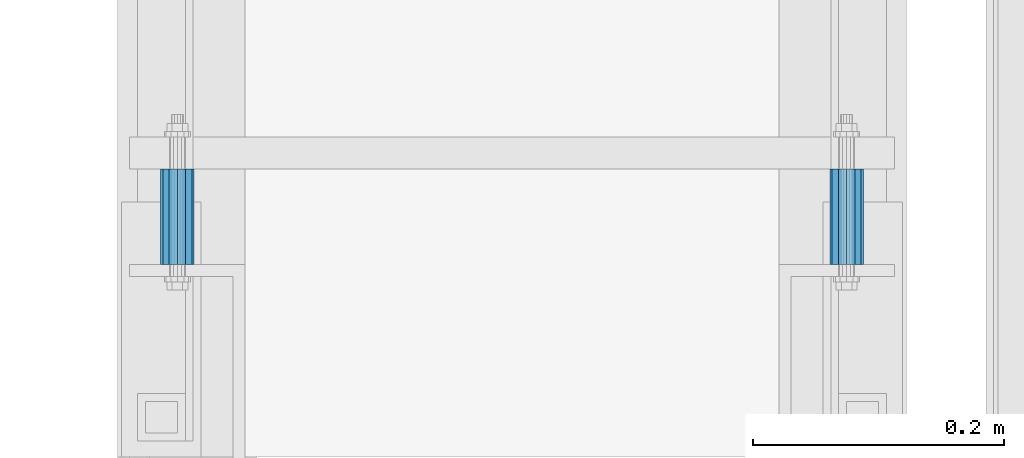
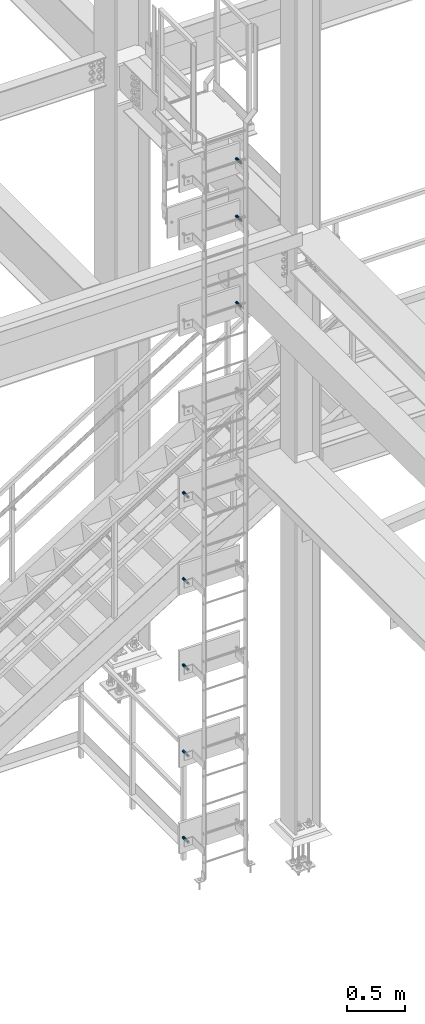
# One storey, part 2873 of 3843: 8 beams, 8 elements without a shape of their own.
"""IFC2X3 building model written with IfcOpenShell, lengths in millimetres."""

from ifc_helpers import new_model, si_unit, frame, origin_with_axes, place, context, subcontext, project, spatial, faceted_brep, material, type_object, element, aggregate, save


model = new_model("IFC2X3")

# Units and contexts
model_context = context("Model", 3, precision=1e-05, world=origin_with_axes())
body_context = subcontext(model_context, "Body", "Model", "MODEL_VIEW")
ifc_project = project(units=[si_unit("LENGTHUNIT", "METRE", prefix="MILLI"), si_unit("AREAUNIT", "SQUARE_METRE"), si_unit("VOLUMEUNIT", "CUBIC_METRE"), si_unit("MASSUNIT", "GRAM", prefix="KILO"), si_unit("TIMEUNIT", "SECOND"), si_unit("PLANEANGLEUNIT", "RADIAN"), si_unit("SOLIDANGLEUNIT", "STERADIAN"), si_unit("THERMODYNAMICTEMPERATUREUNIT", "DEGREE_CELSIUS"), si_unit("LUMINOUSINTENSITYUNIT", "LUMEN")], contexts=[model_context])

# Site, building, storey
site_placement = place(None, origin_with_axes())
site = spatial("IfcSite", under=ifc_project, at=site_placement, CompositionType="ELEMENT")
building_placement = place(site_placement, origin_with_axes())
building = spatial("IfcBuilding", under=site, at=building_placement, Name="Undefined", CompositionType="ELEMENT")
storey_placement = place(building_placement, origin_with_axes())
storey = spatial("IfcBuildingStorey", under=building, at=storey_placement, Name="Undefined", CompositionType="ELEMENT", Elevation=0.0)

# Assembly, beam
assembly_1_placement = place(storey_placement, origin_with_axes())
assembly_1 = element("IfcElementAssembly", 1, at=assembly_1_placement, inside=storey, Name="SLEEVE", AssemblyPlace="NOTDEFINED", PredefinedType="RIGID_FRAME")
ifc_material = material()
beam_type = type_object("IfcBeamType", Name="PIPE3/4SCH40", PredefinedType="NOTDEFINED")
beam_1_placement = place(assembly_1_placement, frame((35623.4999231775, 88507.0189660453, 37797.6364425983), z_axis=(0.0, 2.02899999567308e-06, 0.999999999997942), x_axis=(0.0, 0.999999999997942, -2.02899998962774e-06)))
beam_1 = element("IfcBeam", 2, at=beam_1_placement, type_object=beam_type, material=ifc_material, Name="SLEEVE", ObjectType="PIPE3/4SCH40", context=body_context, shape_type="Brep", body=[
    faceted_brep([(0.0, -10.4648000000016, 7.27595761418343e-12), (-7.27595761418343e-12, -9.06278264552384, 5.23240000000806), (76.2000000004009, -9.06278264552384, 5.2324000001172), (76.2000000004045, -10.4648000000016, 1.16415321826935e-10), (-1.45519152283669e-11, -5.23240000000078, 9.06278264553839), (76.20000000039, -5.23240000000078, 9.06278264564753), (-1.45519152283669e-11, 0.0, 10.4648000000161), (76.20000000039, 0.0, 10.4648000001253), (-1.45519152283669e-11, 5.23240000000078, 9.06278264553839), (76.20000000039, 5.23240000000078, 9.06278264564753), (-7.27595761418343e-12, 9.06278264552384, 5.23240000000806), (76.2000000004009, 9.06278264552384, 5.2324000001172), (0.0, 10.4648000000016, 7.27595761418343e-12), (76.2000000004045, 10.4648000000016, 1.16415321826935e-10), (1.09139364212751e-11, 9.06278264552384, -5.2323999999935), (76.2000000004155, 9.06278264552384, -5.23239999988436), (1.45519152283669e-11, 5.23240000000078, -9.06278264551656), (76.2000000004191, 5.23240000000078, -9.06278264540742), (1.45519152283669e-11, 0.0, -10.4647999999943), (76.2000000004191, 0.0, -10.4647999998851), (1.45519152283669e-11, -5.23240000000078, -9.06278264551656), (76.2000000004191, -5.23240000000078, -9.06278264540742), (1.09139364212751e-11, -9.06278264552384, -5.2323999999935), (76.2000000004155, -9.06278264552384, -5.23239999988436), (0.0, -13.3349999999991, 7.27595761418343e-12), (1.09139364212751e-11, -11.5484487594658, -6.66749999999593), (76.2000000004155, -11.5484487594658, -6.66749999988679), (76.2000000004045, -13.3349999999991, 1.16415321826935e-10), (1.45519152283669e-11, -6.66749999999956, -11.5484487594586), (76.2000000004191, -6.66749999999956, -11.5484487593494), (1.81898940354586e-11, 0.0, -13.3349999999919), (76.2000000004227, 0.0, -13.3349999998827), (1.45519152283669e-11, 6.66749999999956, -11.5484487594586), (76.2000000004191, 6.66749999999956, -11.5484487593494), (1.09139364212751e-11, 11.5484487594658, -6.66749999999593), (76.2000000004155, 11.5484487594658, -6.66749999988679), (0.0, 13.3349999999991, 7.27595761418343e-12), (76.2000000004045, 13.3349999999991, 1.16415321826935e-10), (-7.27595761418343e-12, 11.5484487594658, 6.66750000001048), (76.2000000003973, 11.5484487594658, 6.66750000011234), (-1.45519152283669e-11, 6.66749999999956, 11.5484487594804), (76.20000000039, 6.66749999999956, 11.5484487595895), (-1.81898940354586e-11, 0.0, 13.3350000000137), (76.2000000003864, 0.0, 13.3350000001228), (-1.45519152283669e-11, -6.66749999999956, 11.5484487594804), (76.20000000039, -6.66749999999956, 11.5484487595895), (-7.27595761418343e-12, -11.5484487594658, 6.66750000001048), (76.2000000003973, -11.5484487594658, 6.66750000011234)], [[[0, 1, 2, 3]], [[1, 4, 5, 2]], [[4, 6, 7, 5]], [[6, 8, 9, 7]], [[8, 10, 11, 9]], [[10, 12, 13, 11]], [[12, 14, 15, 13]], [[14, 16, 17, 15]], [[16, 18, 19, 17]], [[18, 20, 21, 19]], [[20, 22, 23, 21]], [[22, 0, 3, 23]], [[24, 25, 26, 27]], [[25, 28, 29, 26]], [[28, 30, 31, 29]], [[30, 32, 33, 31]], [[32, 34, 35, 33]], [[34, 36, 37, 35]], [[36, 38, 39, 37]], [[38, 40, 41, 39]], [[40, 42, 43, 41]], [[42, 44, 45, 43]], [[44, 46, 47, 45]], [[46, 24, 27, 47]], [[29, 31, 33, 35, 37, 39, 41, 43, 45, 47, 27, 26], [5, 7, 9, 11, 13, 15, 17, 19, 21, 23, 3, 2]], [[46, 44, 42, 40, 38, 36, 34, 32, 30, 28, 25, 24], [22, 20, 18, 16, 14, 12, 10, 8, 6, 4, 1, 0]]]),
])
aggregate(assembly_1, [beam_1])

assembly_2_placement = place(storey_placement, origin_with_axes())
assembly_2 = element("IfcElementAssembly", 3, at=assembly_2_placement, inside=storey, Name="SLEEVE", AssemblyPlace="NOTDEFINED", PredefinedType="RIGID_FRAME")
beam_2_placement = place(assembly_2_placement, frame((35623.4999231775, 88507.0189660453, 37188.0364425983), z_axis=(0.0, 2.02899999567308e-06, 0.999999999997942), x_axis=(0.0, 0.999999999997942, -2.02899998962774e-06)))
beam_2 = element("IfcBeam", 4, at=beam_2_placement, type_object=beam_type, material=ifc_material, Name="SLEEVE", ObjectType="PIPE3/4SCH40", context=body_context, shape_type="Brep", body=[
    faceted_brep([(0.0, -10.4648000000016, 7.27595761418343e-12), (-7.27595761418343e-12, -9.06278264552384, 5.23240000000806), (76.2000000004009, -9.06278264552384, 5.2324000001172), (76.2000000004045, -10.4648000000016, 1.16415321826935e-10), (-1.45519152283669e-11, -5.23240000000078, 9.06278264553839), (76.20000000039, -5.23240000000078, 9.06278264564753), (-1.45519152283669e-11, 0.0, 10.4648000000161), (76.20000000039, 0.0, 10.4648000001253), (-1.45519152283669e-11, 5.23240000000078, 9.06278264553839), (76.20000000039, 5.23240000000078, 9.06278264564753), (-7.27595761418343e-12, 9.06278264552384, 5.23240000000806), (76.2000000004009, 9.06278264552384, 5.2324000001172), (0.0, 10.4648000000016, 7.27595761418343e-12), (76.2000000004045, 10.4648000000016, 1.16415321826935e-10), (1.09139364212751e-11, 9.06278264552384, -5.2323999999935), (76.2000000004155, 9.06278264552384, -5.23239999988436), (1.45519152283669e-11, 5.23240000000078, -9.06278264551656), (76.2000000004191, 5.23240000000078, -9.06278264540742), (1.45519152283669e-11, 0.0, -10.4647999999943), (76.2000000004191, 0.0, -10.4647999998851), (1.45519152283669e-11, -5.23240000000078, -9.06278264551656), (76.2000000004191, -5.23240000000078, -9.06278264540742), (1.09139364212751e-11, -9.06278264552384, -5.2323999999935), (76.2000000004155, -9.06278264552384, -5.23239999988436), (0.0, -13.3349999999991, 7.27595761418343e-12), (1.09139364212751e-11, -11.5484487594658, -6.66749999999593), (76.2000000004155, -11.5484487594658, -6.66749999988679), (76.2000000004045, -13.3349999999991, 1.16415321826935e-10), (1.45519152283669e-11, -6.66749999999956, -11.5484487594586), (76.2000000004191, -6.66749999999956, -11.5484487593494), (1.81898940354586e-11, 0.0, -13.3349999999919), (76.2000000004227, 0.0, -13.3349999998827), (1.45519152283669e-11, 6.66749999999956, -11.5484487594586), (76.2000000004191, 6.66749999999956, -11.5484487593494), (1.09139364212751e-11, 11.5484487594658, -6.66749999999593), (76.2000000004155, 11.5484487594658, -6.66749999988679), (0.0, 13.3349999999991, 7.27595761418343e-12), (76.2000000004045, 13.3349999999991, 1.16415321826935e-10), (-7.27595761418343e-12, 11.5484487594658, 6.66750000001048), (76.2000000003973, 11.5484487594658, 6.66750000011234), (-1.45519152283669e-11, 6.66749999999956, 11.5484487594804), (76.20000000039, 6.66749999999956, 11.5484487595895), (-1.81898940354586e-11, 0.0, 13.3350000000137), (76.2000000003864, 0.0, 13.3350000001228), (-1.45519152283669e-11, -6.66749999999956, 11.5484487594804), (76.20000000039, -6.66749999999956, 11.5484487595895), (-7.27595761418343e-12, -11.5484487594658, 6.66750000001048), (76.2000000003973, -11.5484487594658, 6.66750000011234)], [[[0, 1, 2, 3]], [[1, 4, 5, 2]], [[4, 6, 7, 5]], [[6, 8, 9, 7]], [[8, 10, 11, 9]], [[10, 12, 13, 11]], [[12, 14, 15, 13]], [[14, 16, 17, 15]], [[16, 18, 19, 17]], [[18, 20, 21, 19]], [[20, 22, 23, 21]], [[22, 0, 3, 23]], [[24, 25, 26, 27]], [[25, 28, 29, 26]], [[28, 30, 31, 29]], [[30, 32, 33, 31]], [[32, 34, 35, 33]], [[34, 36, 37, 35]], [[36, 38, 39, 37]], [[38, 40, 41, 39]], [[40, 42, 43, 41]], [[42, 44, 45, 43]], [[44, 46, 47, 45]], [[46, 24, 27, 47]], [[29, 31, 33, 35, 37, 39, 41, 43, 45, 47, 27, 26], [5, 7, 9, 11, 13, 15, 17, 19, 21, 23, 3, 2]], [[46, 44, 42, 40, 38, 36, 34, 32, 30, 28, 25, 24], [22, 20, 18, 16, 14, 12, 10, 8, 6, 4, 1, 0]]]),
])
aggregate(assembly_2, [beam_2])

assembly_3_placement = place(storey_placement, origin_with_axes())
assembly_3 = element("IfcElementAssembly", 5, at=assembly_3_placement, inside=storey, Name="SLEEVE", AssemblyPlace="NOTDEFINED", PredefinedType="RIGID_FRAME")
beam_3_placement = place(assembly_3_placement, frame((35623.4999231775, 88507.0189660453, 36273.6364425983), z_axis=(0.0, 2.02899999567308e-06, 0.999999999997942), x_axis=(0.0, 0.999999999997942, -2.02899998962774e-06)))
beam_3 = element("IfcBeam", 6, at=beam_3_placement, type_object=beam_type, material=ifc_material, Name="SLEEVE", ObjectType="PIPE3/4SCH40", context=body_context, shape_type="Brep", body=[
    faceted_brep([(0.0, -10.4648000000016, 7.27595761418343e-12), (-7.27595761418343e-12, -9.06278264552384, 5.23240000000806), (76.2000000004009, -9.06278264552384, 5.2324000001172), (76.2000000004045, -10.4648000000016, 1.16415321826935e-10), (-1.45519152283669e-11, -5.23240000000078, 9.06278264553839), (76.20000000039, -5.23240000000078, 9.06278264564753), (-1.45519152283669e-11, 0.0, 10.4648000000161), (76.20000000039, 0.0, 10.4648000001253), (-1.45519152283669e-11, 5.23240000000078, 9.06278264553839), (76.20000000039, 5.23240000000078, 9.06278264564753), (-7.27595761418343e-12, 9.06278264552384, 5.23240000000806), (76.2000000004009, 9.06278264552384, 5.2324000001172), (0.0, 10.4648000000016, 7.27595761418343e-12), (76.2000000004045, 10.4648000000016, 1.16415321826935e-10), (1.09139364212751e-11, 9.06278264552384, -5.2323999999935), (76.2000000004155, 9.06278264552384, -5.23239999988436), (1.45519152283669e-11, 5.23240000000078, -9.06278264551656), (76.2000000004191, 5.23240000000078, -9.06278264540742), (1.45519152283669e-11, 0.0, -10.4647999999943), (76.2000000004191, 0.0, -10.4647999998851), (1.45519152283669e-11, -5.23240000000078, -9.06278264551656), (76.2000000004191, -5.23240000000078, -9.06278264540742), (1.09139364212751e-11, -9.06278264552384, -5.2323999999935), (76.2000000004155, -9.06278264552384, -5.23239999988436), (0.0, -13.3349999999991, 7.27595761418343e-12), (1.09139364212751e-11, -11.5484487594658, -6.66749999999593), (76.2000000004155, -11.5484487594658, -6.66749999988679), (76.2000000004045, -13.3349999999991, 1.16415321826935e-10), (1.45519152283669e-11, -6.66749999999956, -11.5484487594586), (76.2000000004191, -6.66749999999956, -11.5484487593494), (1.81898940354586e-11, 0.0, -13.3349999999919), (76.2000000004227, 0.0, -13.3349999998827), (1.45519152283669e-11, 6.66749999999956, -11.5484487594586), (76.2000000004191, 6.66749999999956, -11.5484487593494), (1.09139364212751e-11, 11.5484487594658, -6.66749999999593), (76.2000000004155, 11.5484487594658, -6.66749999988679), (0.0, 13.3349999999991, 7.27595761418343e-12), (76.2000000004045, 13.3349999999991, 1.16415321826935e-10), (-7.27595761418343e-12, 11.5484487594658, 6.66750000001048), (76.2000000003973, 11.5484487594658, 6.66750000011234), (-1.45519152283669e-11, 6.66749999999956, 11.5484487594804), (76.20000000039, 6.66749999999956, 11.5484487595895), (-1.81898940354586e-11, 0.0, 13.3350000000137), (76.2000000003864, 0.0, 13.3350000001228), (-1.45519152283669e-11, -6.66749999999956, 11.5484487594804), (76.20000000039, -6.66749999999956, 11.5484487595895), (-7.27595761418343e-12, -11.5484487594658, 6.66750000001048), (76.2000000003973, -11.5484487594658, 6.66750000011234)], [[[0, 1, 2, 3]], [[1, 4, 5, 2]], [[4, 6, 7, 5]], [[6, 8, 9, 7]], [[8, 10, 11, 9]], [[10, 12, 13, 11]], [[12, 14, 15, 13]], [[14, 16, 17, 15]], [[16, 18, 19, 17]], [[18, 20, 21, 19]], [[20, 22, 23, 21]], [[22, 0, 3, 23]], [[24, 25, 26, 27]], [[25, 28, 29, 26]], [[28, 30, 31, 29]], [[30, 32, 33, 31]], [[32, 34, 35, 33]], [[34, 36, 37, 35]], [[36, 38, 39, 37]], [[38, 40, 41, 39]], [[40, 42, 43, 41]], [[42, 44, 45, 43]], [[44, 46, 47, 45]], [[46, 24, 27, 47]], [[29, 31, 33, 35, 37, 39, 41, 43, 45, 47, 27, 26], [5, 7, 9, 11, 13, 15, 17, 19, 21, 23, 3, 2]], [[46, 44, 42, 40, 38, 36, 34, 32, 30, 28, 25, 24], [22, 20, 18, 16, 14, 12, 10, 8, 6, 4, 1, 0]]]),
])
aggregate(assembly_3, [beam_3])

assembly_4_placement = place(storey_placement, origin_with_axes())
assembly_4 = element("IfcElementAssembly", 7, at=assembly_4_placement, inside=storey, Name="SLEEVE", AssemblyPlace="NOTDEFINED", PredefinedType="RIGID_FRAME")
beam_4_placement = place(assembly_4_placement, frame((35090.0999231775, 88507.0189660453, 34444.8364425983), z_axis=(0.0, 2.02899999567308e-06, 0.999999999997942), x_axis=(0.0, 0.999999999997942, -2.02899998962774e-06)))
beam_4 = element("IfcBeam", 8, at=beam_4_placement, type_object=beam_type, material=ifc_material, Name="SLEEVE", ObjectType="PIPE3/4SCH40", context=body_context, shape_type="Brep", body=[
    faceted_brep([(0.0, -10.4648000000016, 7.27595761418343e-12), (-7.27595761418343e-12, -9.06278264552384, 5.23240000000806), (76.2000000004009, -9.06278264552384, 5.2324000001172), (76.2000000004045, -10.4648000000016, 1.16415321826935e-10), (-1.45519152283669e-11, -5.23240000000078, 9.06278264553839), (76.20000000039, -5.23240000000078, 9.06278264564753), (-1.45519152283669e-11, 0.0, 10.4648000000161), (76.20000000039, 0.0, 10.4648000001253), (-1.45519152283669e-11, 5.23240000000078, 9.06278264553839), (76.20000000039, 5.23240000000078, 9.06278264564753), (-7.27595761418343e-12, 9.06278264552384, 5.23240000000806), (76.2000000004009, 9.06278264552384, 5.2324000001172), (0.0, 10.4648000000016, 7.27595761418343e-12), (76.2000000004045, 10.4648000000016, 1.16415321826935e-10), (1.09139364212751e-11, 9.06278264552384, -5.2323999999935), (76.2000000004155, 9.06278264552384, -5.23239999988436), (1.45519152283669e-11, 5.23240000000078, -9.06278264551656), (76.2000000004191, 5.23240000000078, -9.06278264540742), (1.45519152283669e-11, 0.0, -10.4647999999943), (76.2000000004191, 0.0, -10.4647999998851), (1.45519152283669e-11, -5.23240000000078, -9.06278264551656), (76.2000000004191, -5.23240000000078, -9.06278264540742), (1.09139364212751e-11, -9.06278264552384, -5.2323999999935), (76.2000000004155, -9.06278264552384, -5.23239999988436), (0.0, -13.3349999999991, 7.27595761418343e-12), (1.09139364212751e-11, -11.5484487594658, -6.66749999999593), (76.2000000004155, -11.5484487594658, -6.66749999988679), (76.2000000004045, -13.3349999999991, 1.16415321826935e-10), (1.45519152283669e-11, -6.66749999999956, -11.5484487594586), (76.2000000004191, -6.66749999999956, -11.5484487593494), (1.81898940354586e-11, 0.0, -13.3349999999919), (76.2000000004227, 0.0, -13.3349999998827), (1.45519152283669e-11, 6.66749999999956, -11.5484487594586), (76.2000000004191, 6.66749999999956, -11.5484487593494), (1.09139364212751e-11, 11.5484487594658, -6.66749999999593), (76.2000000004155, 11.5484487594658, -6.66749999988679), (0.0, 13.3349999999991, 7.27595761418343e-12), (76.2000000004045, 13.3349999999991, 1.16415321826935e-10), (-7.27595761418343e-12, 11.5484487594658, 6.66750000001048), (76.2000000003973, 11.5484487594658, 6.66750000011234), (-1.45519152283669e-11, 6.66749999999956, 11.5484487594804), (76.20000000039, 6.66749999999956, 11.5484487595895), (-1.81898940354586e-11, 0.0, 13.3350000000137), (76.2000000003864, 0.0, 13.3350000001228), (-1.45519152283669e-11, -6.66749999999956, 11.5484487594804), (76.20000000039, -6.66749999999956, 11.5484487595895), (-7.27595761418343e-12, -11.5484487594658, 6.66750000001048), (76.2000000003973, -11.5484487594658, 6.66750000011234)], [[[0, 1, 2, 3]], [[1, 4, 5, 2]], [[4, 6, 7, 5]], [[6, 8, 9, 7]], [[8, 10, 11, 9]], [[10, 12, 13, 11]], [[12, 14, 15, 13]], [[14, 16, 17, 15]], [[16, 18, 19, 17]], [[18, 20, 21, 19]], [[20, 22, 23, 21]], [[22, 0, 3, 23]], [[24, 25, 26, 27]], [[25, 28, 29, 26]], [[28, 30, 31, 29]], [[30, 32, 33, 31]], [[32, 34, 35, 33]], [[34, 36, 37, 35]], [[36, 38, 39, 37]], [[38, 40, 41, 39]], [[40, 42, 43, 41]], [[42, 44, 45, 43]], [[44, 46, 47, 45]], [[46, 24, 27, 47]], [[29, 31, 33, 35, 37, 39, 41, 43, 45, 47, 27, 26], [5, 7, 9, 11, 13, 15, 17, 19, 21, 23, 3, 2]], [[46, 44, 42, 40, 38, 36, 34, 32, 30, 28, 25, 24], [22, 20, 18, 16, 14, 12, 10, 8, 6, 4, 1, 0]]]),
])
aggregate(assembly_4, [beam_4])

assembly_5_placement = place(storey_placement, origin_with_axes())
assembly_5 = element("IfcElementAssembly", 9, at=assembly_5_placement, inside=storey, Name="SLEEVE", AssemblyPlace="NOTDEFINED", PredefinedType="RIGID_FRAME")
beam_5_placement = place(assembly_5_placement, frame((35090.0999231775, 88507.0189660453, 33530.4364425983), z_axis=(0.0, 2.02899999567308e-06, 0.999999999997942), x_axis=(0.0, 0.999999999997942, -2.02899998962774e-06)))
beam_5 = element("IfcBeam", 10, at=beam_5_placement, type_object=beam_type, material=ifc_material, Name="SLEEVE", ObjectType="PIPE3/4SCH40", context=body_context, shape_type="Brep", body=[
    faceted_brep([(0.0, -10.4648000000016, 7.27595761418343e-12), (-7.27595761418343e-12, -9.06278264552384, 5.23240000000806), (76.2000000004009, -9.06278264552384, 5.2324000001172), (76.2000000004045, -10.4648000000016, 1.16415321826935e-10), (-1.45519152283669e-11, -5.23240000000078, 9.06278264553839), (76.20000000039, -5.23240000000078, 9.06278264564753), (-1.45519152283669e-11, 0.0, 10.4648000000161), (76.20000000039, 0.0, 10.4648000001253), (-1.45519152283669e-11, 5.23240000000078, 9.06278264553839), (76.20000000039, 5.23240000000078, 9.06278264564753), (-7.27595761418343e-12, 9.06278264552384, 5.23240000000806), (76.2000000004009, 9.06278264552384, 5.2324000001172), (0.0, 10.4648000000016, 7.27595761418343e-12), (76.2000000004045, 10.4648000000016, 1.16415321826935e-10), (1.09139364212751e-11, 9.06278264552384, -5.2323999999935), (76.2000000004155, 9.06278264552384, -5.23239999988436), (1.45519152283669e-11, 5.23240000000078, -9.06278264551656), (76.2000000004191, 5.23240000000078, -9.06278264540742), (1.45519152283669e-11, 0.0, -10.4647999999943), (76.2000000004191, 0.0, -10.4647999998851), (1.45519152283669e-11, -5.23240000000078, -9.06278264551656), (76.2000000004191, -5.23240000000078, -9.06278264540742), (1.09139364212751e-11, -9.06278264552384, -5.2323999999935), (76.2000000004155, -9.06278264552384, -5.23239999988436), (0.0, -13.3349999999991, 7.27595761418343e-12), (1.09139364212751e-11, -11.5484487594658, -6.66749999999593), (76.2000000004155, -11.5484487594658, -6.66749999988679), (76.2000000004045, -13.3349999999991, 1.16415321826935e-10), (1.45519152283669e-11, -6.66749999999956, -11.5484487594586), (76.2000000004191, -6.66749999999956, -11.5484487593494), (1.81898940354586e-11, 0.0, -13.3349999999919), (76.2000000004227, 0.0, -13.3349999998827), (1.45519152283669e-11, 6.66749999999956, -11.5484487594586), (76.2000000004191, 6.66749999999956, -11.5484487593494), (1.09139364212751e-11, 11.5484487594658, -6.66749999999593), (76.2000000004155, 11.5484487594658, -6.66749999988679), (0.0, 13.3349999999991, 7.27595761418343e-12), (76.2000000004045, 13.3349999999991, 1.16415321826935e-10), (-7.27595761418343e-12, 11.5484487594658, 6.66750000001048), (76.2000000003973, 11.5484487594658, 6.66750000011234), (-1.45519152283669e-11, 6.66749999999956, 11.5484487594804), (76.20000000039, 6.66749999999956, 11.5484487595895), (-1.81898940354586e-11, 0.0, 13.3350000000137), (76.2000000003864, 0.0, 13.3350000001228), (-1.45519152283669e-11, -6.66749999999956, 11.5484487594804), (76.20000000039, -6.66749999999956, 11.5484487595895), (-7.27595761418343e-12, -11.5484487594658, 6.66750000001048), (76.2000000003973, -11.5484487594658, 6.66750000011234)], [[[0, 1, 2, 3]], [[1, 4, 5, 2]], [[4, 6, 7, 5]], [[6, 8, 9, 7]], [[8, 10, 11, 9]], [[10, 12, 13, 11]], [[12, 14, 15, 13]], [[14, 16, 17, 15]], [[16, 18, 19, 17]], [[18, 20, 21, 19]], [[20, 22, 23, 21]], [[22, 0, 3, 23]], [[24, 25, 26, 27]], [[25, 28, 29, 26]], [[28, 30, 31, 29]], [[30, 32, 33, 31]], [[32, 34, 35, 33]], [[34, 36, 37, 35]], [[36, 38, 39, 37]], [[38, 40, 41, 39]], [[40, 42, 43, 41]], [[42, 44, 45, 43]], [[44, 46, 47, 45]], [[46, 24, 27, 47]], [[29, 31, 33, 35, 37, 39, 41, 43, 45, 47, 27, 26], [5, 7, 9, 11, 13, 15, 17, 19, 21, 23, 3, 2]], [[46, 44, 42, 40, 38, 36, 34, 32, 30, 28, 25, 24], [22, 20, 18, 16, 14, 12, 10, 8, 6, 4, 1, 0]]]),
])
aggregate(assembly_5, [beam_5])

assembly_6_placement = place(storey_placement, origin_with_axes())
assembly_6 = element("IfcElementAssembly", 11, at=assembly_6_placement, inside=storey, Name="SLEEVE", AssemblyPlace="NOTDEFINED", PredefinedType="RIGID_FRAME")
beam_6_placement = place(assembly_6_placement, frame((35090.0999231775, 88507.0189660453, 32616.0364425983), z_axis=(0.0, 2.02899999567308e-06, 0.999999999997942), x_axis=(0.0, 0.999999999997942, -2.02899998962774e-06)))
beam_6 = element("IfcBeam", 12, at=beam_6_placement, type_object=beam_type, material=ifc_material, Name="SLEEVE", ObjectType="PIPE3/4SCH40", context=body_context, shape_type="Brep", body=[
    faceted_brep([(0.0, -10.4648000000016, 7.27595761418343e-12), (-7.27595761418343e-12, -9.06278264552384, 5.23240000000806), (76.2000000004009, -9.06278264552384, 5.2324000001172), (76.2000000004045, -10.4648000000016, 1.16415321826935e-10), (-1.45519152283669e-11, -5.23240000000078, 9.06278264553839), (76.20000000039, -5.23240000000078, 9.06278264564753), (-1.45519152283669e-11, 0.0, 10.4648000000161), (76.20000000039, 0.0, 10.4648000001253), (-1.45519152283669e-11, 5.23240000000078, 9.06278264553839), (76.20000000039, 5.23240000000078, 9.06278264564753), (-7.27595761418343e-12, 9.06278264552384, 5.23240000000806), (76.2000000004009, 9.06278264552384, 5.2324000001172), (0.0, 10.4648000000016, 7.27595761418343e-12), (76.2000000004045, 10.4648000000016, 1.16415321826935e-10), (1.09139364212751e-11, 9.06278264552384, -5.2323999999935), (76.2000000004155, 9.06278264552384, -5.23239999988436), (1.45519152283669e-11, 5.23240000000078, -9.06278264551656), (76.2000000004191, 5.23240000000078, -9.06278264540742), (1.45519152283669e-11, 0.0, -10.4647999999943), (76.2000000004191, 0.0, -10.4647999998851), (1.45519152283669e-11, -5.23240000000078, -9.06278264551656), (76.2000000004191, -5.23240000000078, -9.06278264540742), (1.09139364212751e-11, -9.06278264552384, -5.2323999999935), (76.2000000004155, -9.06278264552384, -5.23239999988436), (0.0, -13.3349999999991, 7.27595761418343e-12), (1.09139364212751e-11, -11.5484487594658, -6.66749999999593), (76.2000000004155, -11.5484487594658, -6.66749999988679), (76.2000000004045, -13.3349999999991, 1.16415321826935e-10), (1.45519152283669e-11, -6.66749999999956, -11.5484487594586), (76.2000000004191, -6.66749999999956, -11.5484487593494), (1.81898940354586e-11, 0.0, -13.3349999999919), (76.2000000004227, 0.0, -13.3349999998827), (1.45519152283669e-11, 6.66749999999956, -11.5484487594586), (76.2000000004191, 6.66749999999956, -11.5484487593494), (1.09139364212751e-11, 11.5484487594658, -6.66749999999593), (76.2000000004155, 11.5484487594658, -6.66749999988679), (0.0, 13.3349999999991, 7.27595761418343e-12), (76.2000000004045, 13.3349999999991, 1.16415321826935e-10), (-7.27595761418343e-12, 11.5484487594658, 6.66750000001048), (76.2000000003973, 11.5484487594658, 6.66750000011234), (-1.45519152283669e-11, 6.66749999999956, 11.5484487594804), (76.20000000039, 6.66749999999956, 11.5484487595895), (-1.81898940354586e-11, 0.0, 13.3350000000137), (76.2000000003864, 0.0, 13.3350000001228), (-1.45519152283669e-11, -6.66749999999956, 11.5484487594804), (76.20000000039, -6.66749999999956, 11.5484487595895), (-7.27595761418343e-12, -11.5484487594658, 6.66750000001048), (76.2000000003973, -11.5484487594658, 6.66750000011234)], [[[0, 1, 2, 3]], [[1, 4, 5, 2]], [[4, 6, 7, 5]], [[6, 8, 9, 7]], [[8, 10, 11, 9]], [[10, 12, 13, 11]], [[12, 14, 15, 13]], [[14, 16, 17, 15]], [[16, 18, 19, 17]], [[18, 20, 21, 19]], [[20, 22, 23, 21]], [[22, 0, 3, 23]], [[24, 25, 26, 27]], [[25, 28, 29, 26]], [[28, 30, 31, 29]], [[30, 32, 33, 31]], [[32, 34, 35, 33]], [[34, 36, 37, 35]], [[36, 38, 39, 37]], [[38, 40, 41, 39]], [[40, 42, 43, 41]], [[42, 44, 45, 43]], [[44, 46, 47, 45]], [[46, 24, 27, 47]], [[29, 31, 33, 35, 37, 39, 41, 43, 45, 47, 27, 26], [5, 7, 9, 11, 13, 15, 17, 19, 21, 23, 3, 2]], [[46, 44, 42, 40, 38, 36, 34, 32, 30, 28, 25, 24], [22, 20, 18, 16, 14, 12, 10, 8, 6, 4, 1, 0]]]),
])
aggregate(assembly_6, [beam_6])

assembly_7_placement = place(storey_placement, origin_with_axes())
assembly_7 = element("IfcElementAssembly", 13, at=assembly_7_placement, inside=storey, Name="SLEEVE", AssemblyPlace="NOTDEFINED", PredefinedType="RIGID_FRAME")
beam_7_placement = place(assembly_7_placement, frame((35090.0999231775, 88507.0189660453, 31701.6364425983), z_axis=(0.0, 2.02899999567308e-06, 0.999999999997942), x_axis=(0.0, 0.999999999997942, -2.02899998962774e-06)))
beam_7 = element("IfcBeam", 14, at=beam_7_placement, type_object=beam_type, material=ifc_material, Name="SLEEVE", ObjectType="PIPE3/4SCH40", context=body_context, shape_type="Brep", body=[
    faceted_brep([(0.0, -10.4648000000016, 7.27595761418343e-12), (-7.27595761418343e-12, -9.06278264552384, 5.23240000000806), (76.2000000004009, -9.06278264552384, 5.2324000001172), (76.2000000004045, -10.4648000000016, 1.16415321826935e-10), (-1.45519152283669e-11, -5.23240000000078, 9.06278264553839), (76.20000000039, -5.23240000000078, 9.06278264564753), (-1.45519152283669e-11, 0.0, 10.4648000000161), (76.20000000039, 0.0, 10.4648000001253), (-1.45519152283669e-11, 5.23240000000078, 9.06278264553839), (76.20000000039, 5.23240000000078, 9.06278264564753), (-7.27595761418343e-12, 9.06278264552384, 5.23240000000806), (76.2000000004009, 9.06278264552384, 5.2324000001172), (0.0, 10.4648000000016, 7.27595761418343e-12), (76.2000000004045, 10.4648000000016, 1.16415321826935e-10), (1.09139364212751e-11, 9.06278264552384, -5.2323999999935), (76.2000000004155, 9.06278264552384, -5.23239999988436), (1.45519152283669e-11, 5.23240000000078, -9.06278264551656), (76.2000000004191, 5.23240000000078, -9.06278264540742), (1.45519152283669e-11, 0.0, -10.4647999999943), (76.2000000004191, 0.0, -10.4647999998851), (1.45519152283669e-11, -5.23240000000078, -9.06278264551656), (76.2000000004191, -5.23240000000078, -9.06278264540742), (1.09139364212751e-11, -9.06278264552384, -5.2323999999935), (76.2000000004155, -9.06278264552384, -5.23239999988436), (0.0, -13.3349999999991, 7.27595761418343e-12), (1.09139364212751e-11, -11.5484487594658, -6.66749999999593), (76.2000000004155, -11.5484487594658, -6.66749999988679), (76.2000000004045, -13.3349999999991, 1.16415321826935e-10), (1.45519152283669e-11, -6.66749999999956, -11.5484487594586), (76.2000000004191, -6.66749999999956, -11.5484487593494), (1.81898940354586e-11, 0.0, -13.3349999999919), (76.2000000004227, 0.0, -13.3349999998827), (1.45519152283669e-11, 6.66749999999956, -11.5484487594586), (76.2000000004191, 6.66749999999956, -11.5484487593494), (1.09139364212751e-11, 11.5484487594658, -6.66749999999593), (76.2000000004155, 11.5484487594658, -6.66749999988679), (0.0, 13.3349999999991, 7.27595761418343e-12), (76.2000000004045, 13.3349999999991, 1.16415321826935e-10), (-7.27595761418343e-12, 11.5484487594658, 6.66750000001048), (76.2000000003973, 11.5484487594658, 6.66750000011234), (-1.45519152283669e-11, 6.66749999999956, 11.5484487594804), (76.20000000039, 6.66749999999956, 11.5484487595895), (-1.81898940354586e-11, 0.0, 13.3350000000137), (76.2000000003864, 0.0, 13.3350000001228), (-1.45519152283669e-11, -6.66749999999956, 11.5484487594804), (76.20000000039, -6.66749999999956, 11.5484487595895), (-7.27595761418343e-12, -11.5484487594658, 6.66750000001048), (76.2000000003973, -11.5484487594658, 6.66750000011234)], [[[0, 1, 2, 3]], [[1, 4, 5, 2]], [[4, 6, 7, 5]], [[6, 8, 9, 7]], [[8, 10, 11, 9]], [[10, 12, 13, 11]], [[12, 14, 15, 13]], [[14, 16, 17, 15]], [[16, 18, 19, 17]], [[18, 20, 21, 19]], [[20, 22, 23, 21]], [[22, 0, 3, 23]], [[24, 25, 26, 27]], [[25, 28, 29, 26]], [[28, 30, 31, 29]], [[30, 32, 33, 31]], [[32, 34, 35, 33]], [[34, 36, 37, 35]], [[36, 38, 39, 37]], [[38, 40, 41, 39]], [[40, 42, 43, 41]], [[42, 44, 45, 43]], [[44, 46, 47, 45]], [[46, 24, 27, 47]], [[29, 31, 33, 35, 37, 39, 41, 43, 45, 47, 27, 26], [5, 7, 9, 11, 13, 15, 17, 19, 21, 23, 3, 2]], [[46, 44, 42, 40, 38, 36, 34, 32, 30, 28, 25, 24], [22, 20, 18, 16, 14, 12, 10, 8, 6, 4, 1, 0]]]),
])
aggregate(assembly_7, [beam_7])

assembly_8_placement = place(storey_placement, origin_with_axes())
assembly_8 = element("IfcElementAssembly", 15, at=assembly_8_placement, inside=storey, Name="SLEEVE", AssemblyPlace="NOTDEFINED", PredefinedType="RIGID_FRAME")
beam_8_placement = place(assembly_8_placement, frame((35090.0999231775, 88507.0189660453, 30787.2364425983), z_axis=(0.0, 2.02899999567308e-06, 0.999999999997942), x_axis=(0.0, 0.999999999997942, -2.02899998962774e-06)))
beam_8 = element("IfcBeam", 16, at=beam_8_placement, type_object=beam_type, material=ifc_material, Name="SLEEVE", ObjectType="PIPE3/4SCH40", context=body_context, shape_type="Brep", body=[
    faceted_brep([(0.0, -10.4648000000016, 7.27595761418343e-12), (-7.27595761418343e-12, -9.06278264552384, 5.23240000000806), (76.2000000004009, -9.06278264552384, 5.2324000001172), (76.2000000004045, -10.4648000000016, 1.16415321826935e-10), (-1.45519152283669e-11, -5.23240000000078, 9.06278264553839), (76.20000000039, -5.23240000000078, 9.06278264564753), (-1.45519152283669e-11, 0.0, 10.4648000000161), (76.20000000039, 0.0, 10.4648000001253), (-1.45519152283669e-11, 5.23240000000078, 9.06278264553839), (76.20000000039, 5.23240000000078, 9.06278264564753), (-7.27595761418343e-12, 9.06278264552384, 5.23240000000806), (76.2000000004009, 9.06278264552384, 5.2324000001172), (0.0, 10.4648000000016, 7.27595761418343e-12), (76.2000000004045, 10.4648000000016, 1.16415321826935e-10), (1.09139364212751e-11, 9.06278264552384, -5.2323999999935), (76.2000000004155, 9.06278264552384, -5.23239999988436), (1.45519152283669e-11, 5.23240000000078, -9.06278264551656), (76.2000000004191, 5.23240000000078, -9.06278264540742), (1.45519152283669e-11, 0.0, -10.4647999999943), (76.2000000004191, 0.0, -10.4647999998851), (1.45519152283669e-11, -5.23240000000078, -9.06278264551656), (76.2000000004191, -5.23240000000078, -9.06278264540742), (1.09139364212751e-11, -9.06278264552384, -5.2323999999935), (76.2000000004155, -9.06278264552384, -5.23239999988436), (0.0, -13.3349999999991, 7.27595761418343e-12), (1.09139364212751e-11, -11.5484487594658, -6.66749999999593), (76.2000000004155, -11.5484487594658, -6.66749999988679), (76.2000000004045, -13.3349999999991, 1.16415321826935e-10), (1.45519152283669e-11, -6.66749999999956, -11.5484487594586), (76.2000000004191, -6.66749999999956, -11.5484487593494), (1.81898940354586e-11, 0.0, -13.3349999999919), (76.2000000004227, 0.0, -13.3349999998827), (1.45519152283669e-11, 6.66749999999956, -11.5484487594586), (76.2000000004191, 6.66749999999956, -11.5484487593494), (1.09139364212751e-11, 11.5484487594658, -6.66749999999593), (76.2000000004155, 11.5484487594658, -6.66749999988679), (0.0, 13.3349999999991, 7.27595761418343e-12), (76.2000000004045, 13.3349999999991, 1.16415321826935e-10), (-7.27595761418343e-12, 11.5484487594658, 6.66750000001048), (76.2000000003973, 11.5484487594658, 6.66750000011234), (-1.45519152283669e-11, 6.66749999999956, 11.5484487594804), (76.20000000039, 6.66749999999956, 11.5484487595895), (-1.81898940354586e-11, 0.0, 13.3350000000137), (76.2000000003864, 0.0, 13.3350000001228), (-1.45519152283669e-11, -6.66749999999956, 11.5484487594804), (76.20000000039, -6.66749999999956, 11.5484487595895), (-7.27595761418343e-12, -11.5484487594658, 6.66750000001048), (76.2000000003973, -11.5484487594658, 6.66750000011234)], [[[0, 1, 2, 3]], [[1, 4, 5, 2]], [[4, 6, 7, 5]], [[6, 8, 9, 7]], [[8, 10, 11, 9]], [[10, 12, 13, 11]], [[12, 14, 15, 13]], [[14, 16, 17, 15]], [[16, 18, 19, 17]], [[18, 20, 21, 19]], [[20, 22, 23, 21]], [[22, 0, 3, 23]], [[24, 25, 26, 27]], [[25, 28, 29, 26]], [[28, 30, 31, 29]], [[30, 32, 33, 31]], [[32, 34, 35, 33]], [[34, 36, 37, 35]], [[36, 38, 39, 37]], [[38, 40, 41, 39]], [[40, 42, 43, 41]], [[42, 44, 45, 43]], [[44, 46, 47, 45]], [[46, 24, 27, 47]], [[29, 31, 33, 35, 37, 39, 41, 43, 45, 47, 27, 26], [5, 7, 9, 11, 13, 15, 17, 19, 21, 23, 3, 2]], [[46, 44, 42, 40, 38, 36, 34, 32, 30, 28, 25, 24], [22, 20, 18, 16, 14, 12, 10, 8, 6, 4, 1, 0]]]),
])
aggregate(assembly_8, [beam_8])

save(model, "model.ifc")
